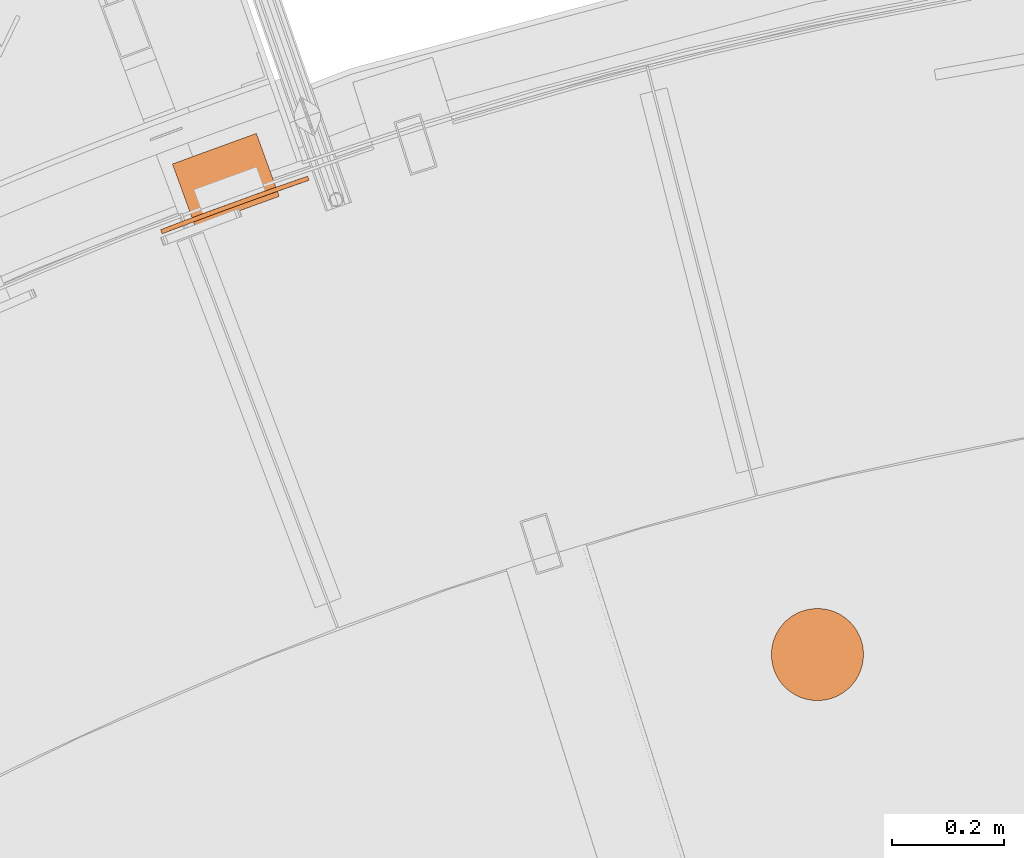
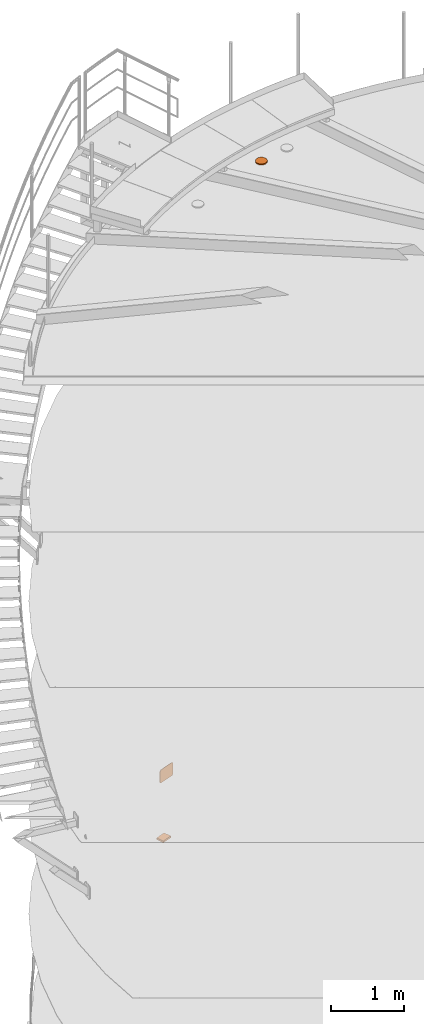
# One storey, part 87 of 126: 3 proxies.
"""IFC2X3 building model written with IfcOpenShell, lengths in millimetres."""

from ifc_helpers import new_model, si_unit, origin, origin_with_axes, place, context, project, spatial, faceted_brep, material, element, save


model = new_model("IFC2X3")

# Units and contexts
context_of_model_1 = context(None, 3, precision=0.1, world=origin())
context_of_model_2 = context(None, 3, precision=0.1, world=origin())
ifc_project = project(units=[si_unit("LENGTHUNIT", "METRE", prefix="MILLI"), si_unit("AREAUNIT", "SQUARE_METRE", prefix="CENTI"), si_unit("VOLUMEUNIT", "CUBIC_METRE", prefix="CENTI"), si_unit("MASSUNIT", "GRAM", prefix="KILO")], contexts=[context_of_model_1, context_of_model_2])

# Site, building, storey
site_placement = place(None, origin_with_axes())
site = spatial("IfcSite", under=ifc_project, at=site_placement, CompositionType="ELEMENT")
building_placement = place(site_placement, origin_with_axes())
building = spatial("IfcBuilding", under=site, at=building_placement, CompositionType="ELEMENT")
storey_placement = place(building_placement, origin_with_axes())
storey = spatial("IfcBuildingStorey", under=building, at=storey_placement, CompositionType="ELEMENT")

# Proxies
ifc_material = material(Name="STAHL")
proxy_1_placement = place(storey_placement, origin_with_axes())
element("IfcBuildingElementProxy", 1, at=proxy_1_placement, inside=storey, material=ifc_material, Name="profile", context=context_of_model_2, shape_type="Brep", body=[
    faceted_brep([(6309.1, 14601.6, 10998.9), (6309.1, 14601.6, 10979.9), (6304.0, 14594.6, 10979.9), (6304.0, 14594.6, 10998.9), (6314.9, 14608.0, 10998.9), (6314.9, 14608.0, 10979.9), (6454.7, 14562.6, 10998.9), (6454.7, 14562.6, 10979.9), (6452.9, 14571.0, 10979.9), (6452.9, 14571.0, 10998.9), (6299.7, 14587.1, 10979.9), (6299.7, 14587.1, 10998.9), (6450.3, 14579.2, 10979.9), (6450.3, 14579.2, 10998.9), (6296.2, 14579.2, 10979.9), (6296.2, 14579.2, 10998.9), (6446.7, 14587.1, 10979.9), (6446.7, 14587.1, 10998.9), (6293.5, 14571.0, 10979.9), (6293.5, 14571.0, 10998.9), (6442.4, 14594.6, 10979.9), (6442.4, 14594.6, 10998.9), (6291.8, 14562.6, 10979.9), (6291.8, 14562.6, 10998.9), (6437.4, 14601.6, 10979.9), (6437.4, 14601.6, 10998.9), (6290.8, 14554.0, 10979.9), (6290.8, 14554.0, 10998.9), (6431.6, 14608.0, 10979.9), (6431.6, 14608.0, 10998.9), (6290.8, 14545.3, 10979.9), (6290.8, 14545.3, 10998.9), (6425.2, 14613.8, 10979.9), (6425.2, 14613.8, 10998.9), (6291.8, 14536.7, 10979.9), (6291.8, 14536.7, 10998.9), (6418.2, 14618.8, 10979.9), (6418.2, 14618.8, 10998.9), (6410.7, 14623.2, 10979.9), (6410.7, 14623.2, 10998.9), (6402.8, 14626.7, 10979.9), (6402.8, 14626.7, 10998.9), (6394.6, 14629.3, 10979.9), (6394.6, 14629.3, 10998.9), (6386.1, 14631.1, 10979.9), (6386.1, 14631.1, 10998.9), (6377.6, 14632.0, 10979.9), (6377.6, 14632.0, 10998.9), (6368.9, 14632.0, 10979.9), (6368.9, 14632.0, 10998.9), (6360.3, 14631.1, 10979.9), (6360.3, 14631.1, 10998.9), (6351.9, 14629.3, 10979.9), (6351.9, 14629.3, 10998.9), (6343.7, 14626.7, 10979.9), (6343.7, 14626.7, 10998.9), (6335.8, 14623.2, 10979.9), (6335.8, 14623.2, 10998.9), (6328.3, 14618.8, 10979.9), (6328.3, 14618.8, 10998.9), (6321.3, 14613.8, 10979.9), (6321.3, 14613.8, 10998.9), (6403.6, 14554.5, 10998.9), (6402.3, 14559.7, 10998.9), (6402.3, 14559.7, 10979.9), (6403.6, 14554.5, 10979.9), (6400.1, 14564.6, 10998.9), (6400.1, 14564.6, 10979.9), (6397.1, 14569.0, 10998.9), (6397.1, 14569.0, 10979.9), (6393.4, 14572.9, 10998.9), (6393.4, 14572.9, 10979.9), (6389.1, 14576.0, 10998.9), (6389.1, 14576.0, 10979.9), (6384.3, 14578.4, 10998.9), (6384.3, 14578.4, 10979.9), (6379.1, 14579.8, 10998.9), (6379.1, 14579.8, 10979.9), (6373.8, 14580.4, 10998.9), (6373.8, 14580.4, 10979.9), (6368.4, 14580.0, 10998.9), (6368.4, 14580.0, 10979.9), (6363.2, 14578.7, 10998.9), (6363.2, 14578.7, 10979.9), (6358.3, 14576.5, 10998.9), (6358.3, 14576.5, 10979.9), (6353.9, 14573.5, 10998.9), (6353.9, 14573.5, 10979.9), (6350.0, 14569.8, 10998.9), (6350.0, 14569.8, 10979.9), (6346.9, 14565.5, 10998.9), (6346.9, 14565.5, 10979.9), (6344.5, 14560.7, 10998.9), (6344.5, 14560.7, 10979.9), (6343.1, 14555.5, 10998.9), (6343.1, 14555.5, 10979.9), (6342.5, 14550.2, 10998.9), (6342.5, 14550.2, 10979.9), (6342.9, 14544.8, 10998.9), (6342.9, 14544.8, 10979.9), (6432.7, 14514.3, 10998.9), (6432.1, 14516.4, 10998.9), (6432.1, 14516.4, 10979.9), (6432.7, 14514.3, 10979.9), (6431.0, 14518.3, 10998.9), (6431.0, 14518.3, 10979.9), (6429.5, 14519.9, 10998.9), (6429.5, 14519.9, 10979.9), (6427.7, 14521.0, 10998.9), (6427.7, 14521.0, 10979.9), (6425.6, 14521.7, 10998.9), (6425.6, 14521.7, 10979.9), (6423.5, 14521.9, 10998.9), (6423.5, 14521.9, 10979.9), (6421.3, 14521.6, 10998.9), (6421.3, 14521.6, 10979.9), (6419.3, 14520.7, 10998.9), (6419.3, 14520.7, 10979.9), (6417.6, 14519.4, 10998.9), (6417.6, 14519.4, 10979.9), (6416.2, 14517.7, 10998.9), (6416.2, 14517.7, 10979.9), (6415.3, 14515.8, 10998.9), (6415.3, 14515.8, 10979.9), (6414.8, 14513.7, 10998.9), (6414.8, 14513.7, 10979.9), (6414.9, 14511.5, 10998.9), (6414.9, 14511.5, 10979.9), (6331.6, 14587.8, 10998.9), (6331.0, 14589.9, 10998.9), (6331.0, 14589.9, 10979.9), (6331.6, 14587.8, 10979.9), (6329.9, 14591.8, 10998.9), (6329.9, 14591.8, 10979.9), (6328.4, 14593.3, 10998.9), (6328.4, 14593.3, 10979.9), (6326.6, 14594.5, 10998.9), (6326.6, 14594.5, 10979.9), (6324.5, 14595.2, 10998.9), (6324.5, 14595.2, 10979.9), (6322.3, 14595.4, 10998.9), (6322.3, 14595.4, 10979.9), (6320.2, 14595.0, 10998.9), (6320.2, 14595.0, 10979.9), (6318.2, 14594.2, 10998.9), (6318.2, 14594.2, 10979.9), (6316.5, 14592.9, 10998.9), (6316.5, 14592.9, 10979.9), (6315.1, 14591.2, 10998.9), (6315.1, 14591.2, 10979.9), (6314.1, 14589.3, 10998.9), (6314.1, 14589.3, 10979.9), (6313.7, 14587.1, 10998.9), (6313.7, 14587.1, 10979.9), (6313.8, 14585.0, 10998.9), (6313.8, 14585.0, 10979.9), (6418.9, 14601.6, 10998.9), (6418.3, 14603.7, 10998.9), (6418.3, 14603.7, 10979.9), (6418.9, 14601.6, 10979.9), (6417.2, 14605.6, 10998.9), (6417.2, 14605.6, 10979.9), (6415.7, 14607.2, 10998.9), (6415.7, 14607.2, 10979.9), (6413.9, 14608.3, 10998.9), (6413.9, 14608.3, 10979.9), (6411.8, 14609.0, 10998.9), (6411.8, 14609.0, 10979.9), (6409.6, 14609.2, 10998.9), (6409.6, 14609.2, 10979.9), (6407.5, 14608.9, 10998.9), (6407.5, 14608.9, 10979.9), (6405.5, 14608.0, 10998.9), (6405.5, 14608.0, 10979.9), (6403.8, 14606.7, 10998.9), (6403.8, 14606.7, 10979.9), (6402.4, 14605.0, 10998.9), (6402.4, 14605.0, 10979.9), (6401.4, 14603.1, 10998.9), (6401.4, 14603.1, 10979.9), (6401.0, 14601.0, 10998.9), (6401.0, 14601.0, 10979.9), (6401.1, 14598.8, 10998.9), (6401.1, 14598.8, 10979.9), (6345.4, 14500.5, 10998.9), (6344.8, 14502.6, 10998.9), (6344.8, 14502.6, 10979.9), (6345.4, 14500.5, 10979.9), (6343.7, 14504.5, 10998.9), (6343.7, 14504.5, 10979.9), (6342.2, 14506.0, 10998.9), (6342.2, 14506.0, 10979.9), (6340.4, 14507.2, 10998.9), (6340.4, 14507.2, 10979.9), (6338.3, 14507.9, 10998.9), (6338.3, 14507.9, 10979.9), (6336.2, 14508.1, 10998.9), (6336.2, 14508.1, 10979.9), (6334.0, 14507.7, 10998.9), (6334.0, 14507.7, 10979.9), (6332.0, 14506.9, 10998.9), (6332.0, 14506.9, 10979.9), (6330.3, 14505.6, 10998.9), (6330.3, 14505.6, 10979.9), (6328.9, 14503.9, 10998.9), (6328.9, 14503.9, 10979.9), (6328.0, 14502.0, 10998.9), (6328.0, 14502.0, 10979.9), (6327.5, 14499.8, 10998.9), (6327.5, 14499.8, 10979.9), (6327.6, 14497.7, 10998.9), (6327.6, 14497.7, 10979.9), (6328.2, 14495.6, 10998.9), (6328.2, 14495.6, 10979.9), (6329.3, 14493.7, 10998.9), (6329.3, 14493.7, 10979.9), (6330.8, 14492.1, 10998.9), (6330.8, 14492.1, 10979.9), (6332.6, 14491.0, 10998.9), (6332.6, 14491.0, 10979.9), (6334.7, 14490.3, 10998.9), (6334.7, 14490.3, 10979.9), (6336.8, 14490.1, 10998.9), (6336.8, 14490.1, 10979.9), (6339.0, 14490.4, 10998.9), (6339.0, 14490.4, 10979.9), (6341.0, 14491.3, 10998.9), (6341.0, 14491.3, 10979.9), (6342.7, 14492.6, 10998.9), (6342.7, 14492.6, 10979.9), (6344.1, 14494.2, 10998.9), (6344.1, 14494.2, 10979.9), (6345.0, 14496.2, 10998.9), (6345.0, 14496.2, 10979.9), (6345.5, 14498.3, 10998.9), (6345.5, 14498.3, 10979.9), (6401.7, 14596.7, 10998.9), (6401.7, 14596.7, 10979.9), (6402.8, 14594.8, 10998.9), (6402.8, 14594.8, 10979.9), (6404.3, 14593.3, 10998.9), (6404.3, 14593.3, 10979.9), (6406.1, 14592.1, 10998.9), (6406.1, 14592.1, 10979.9), (6408.1, 14591.4, 10998.9), (6408.1, 14591.4, 10979.9), (6410.3, 14591.2, 10998.9), (6410.3, 14591.2, 10979.9), (6412.4, 14591.6, 10998.9), (6412.4, 14591.6, 10979.9), (6414.4, 14592.4, 10998.9), (6414.4, 14592.4, 10979.9), (6416.2, 14593.7, 10998.9), (6416.2, 14593.7, 10979.9), (6417.6, 14595.4, 10998.9), (6417.6, 14595.4, 10979.9), (6418.5, 14597.3, 10998.9), (6418.5, 14597.3, 10979.9), (6418.9, 14599.4, 10998.9), (6418.9, 14599.4, 10979.9), (6314.4, 14582.9, 10998.9), (6314.4, 14582.9, 10979.9), (6315.5, 14581.0, 10998.9), (6315.5, 14581.0, 10979.9), (6317.0, 14579.4, 10998.9), (6317.0, 14579.4, 10979.9), (6318.8, 14578.3, 10998.9), (6318.8, 14578.3, 10979.9), (6320.8, 14577.6, 10998.9), (6320.8, 14577.6, 10979.9), (6323.0, 14577.4, 10998.9), (6323.0, 14577.4, 10979.9), (6325.1, 14577.7, 10998.9), (6325.1, 14577.7, 10979.9), (6327.1, 14578.6, 10998.9), (6327.1, 14578.6, 10979.9), (6328.9, 14579.9, 10998.9), (6328.9, 14579.9, 10979.9), (6330.3, 14581.5, 10998.9), (6330.3, 14581.5, 10979.9), (6331.2, 14583.5, 10998.9), (6331.2, 14583.5, 10979.9), (6331.6, 14585.6, 10998.9), (6331.6, 14585.6, 10979.9), (6415.5, 14509.4, 10998.9), (6415.5, 14509.4, 10979.9), (6416.6, 14507.5, 10998.9), (6416.6, 14507.5, 10979.9), (6418.1, 14506.0, 10998.9), (6418.1, 14506.0, 10979.9), (6419.9, 14504.8, 10998.9), (6419.9, 14504.8, 10979.9), (6422.0, 14504.1, 10998.9), (6422.0, 14504.1, 10979.9), (6424.1, 14503.9, 10998.9), (6424.1, 14503.9, 10979.9), (6426.3, 14504.3, 10998.9), (6426.3, 14504.3, 10979.9), (6428.3, 14505.1, 10998.9), (6428.3, 14505.1, 10979.9), (6430.0, 14506.4, 10998.9), (6430.0, 14506.4, 10979.9), (6431.4, 14508.1, 10998.9), (6431.4, 14508.1, 10979.9), (6432.3, 14510.0, 10998.9), (6432.3, 14510.0, 10979.9), (6432.8, 14512.1, 10998.9), (6432.8, 14512.1, 10979.9), (6368.9, 14467.3, 10998.9), (6377.6, 14467.3, 10998.9), (6386.1, 14468.2, 10998.9), (6394.6, 14470.0, 10998.9), (6402.8, 14472.6, 10998.9), (6410.7, 14476.1, 10998.9), (6418.2, 14480.5, 10998.9), (6425.2, 14485.5, 10998.9), (6431.6, 14491.3, 10998.9), (6437.4, 14497.7, 10998.9), (6442.4, 14504.7, 10998.9), (6446.7, 14512.2, 10998.9), (6450.3, 14520.1, 10998.9), (6452.9, 14528.3, 10998.9), (6404.0, 14549.1, 10998.9), (6403.4, 14543.8, 10998.9), (6401.9, 14538.6, 10998.9), (6399.6, 14533.8, 10998.9), (6396.4, 14529.5, 10998.9), (6392.6, 14525.7, 10998.9), (6388.1, 14522.8, 10998.9), (6383.2, 14520.6, 10998.9), (6378.0, 14519.3, 10998.9), (6372.7, 14518.9, 10998.9), (6367.4, 14519.5, 10998.9), (6362.2, 14520.9, 10998.9), (6357.4, 14523.3, 10998.9), (6353.1, 14526.4, 10998.9), (6349.3, 14530.3, 10998.9), (6346.3, 14534.7, 10998.9), (6344.2, 14539.6, 10998.9), (6454.7, 14536.7, 10998.9), (6455.6, 14545.3, 10998.9), (6455.6, 14554.0, 10998.9), (6293.5, 14528.3, 10998.9), (6296.2, 14520.1, 10998.9), (6299.7, 14512.2, 10998.9), (6304.0, 14504.7, 10998.9), (6309.1, 14497.7, 10998.9), (6314.9, 14491.3, 10998.9), (6321.3, 14485.5, 10998.9), (6328.3, 14480.5, 10998.9), (6335.8, 14476.1, 10998.9), (6343.7, 14472.6, 10998.9), (6351.9, 14470.0, 10998.9), (6360.3, 14468.2, 10998.9), (6368.9, 14467.3, 10979.9), (6360.3, 14468.2, 10979.9), (6351.9, 14470.0, 10979.9), (6343.7, 14472.6, 10979.9), (6335.8, 14476.1, 10979.9), (6328.3, 14480.5, 10979.9), (6321.3, 14485.5, 10979.9), (6314.9, 14491.3, 10979.9), (6309.1, 14497.7, 10979.9), (6304.0, 14504.7, 10979.9), (6299.7, 14512.2, 10979.9), (6296.2, 14520.1, 10979.9), (6293.5, 14528.3, 10979.9), (6455.6, 14554.0, 10979.9), (6455.6, 14545.3, 10979.9), (6454.7, 14536.7, 10979.9), (6452.9, 14528.3, 10979.9), (6383.2, 14520.6, 10979.9), (6388.1, 14522.8, 10979.9), (6392.6, 14525.7, 10979.9), (6396.4, 14529.5, 10979.9), (6399.6, 14533.8, 10979.9), (6401.9, 14538.6, 10979.9), (6403.4, 14543.8, 10979.9), (6404.0, 14549.1, 10979.9), (6344.2, 14539.6, 10979.9), (6346.3, 14534.7, 10979.9), (6349.3, 14530.3, 10979.9), (6353.1, 14526.4, 10979.9), (6357.4, 14523.3, 10979.9), (6362.2, 14520.9, 10979.9), (6367.4, 14519.5, 10979.9), (6372.7, 14518.9, 10979.9), (6378.0, 14519.3, 10979.9), (6450.3, 14520.1, 10979.9), (6446.7, 14512.2, 10979.9), (6442.4, 14504.7, 10979.9), (6437.4, 14497.7, 10979.9), (6431.6, 14491.3, 10979.9), (6425.2, 14485.5, 10979.9), (6418.2, 14480.5, 10979.9), (6410.7, 14476.1, 10979.9), (6402.8, 14472.6, 10979.9), (6394.6, 14470.0, 10979.9), (6386.1, 14468.2, 10979.9), (6377.6, 14467.3, 10979.9)], [[[0, 1, 2, 3]], [[0, 4, 5, 1]], [[6, 7, 8, 9]], [[3, 2, 10, 11]], [[9, 8, 12, 13]], [[11, 10, 14, 15]], [[13, 12, 16, 17]], [[15, 14, 18, 19]], [[17, 16, 20, 21]], [[19, 18, 22, 23]], [[21, 20, 24, 25]], [[23, 22, 26, 27]], [[25, 24, 28, 29]], [[27, 26, 30, 31]], [[29, 28, 32, 33]], [[31, 30, 34, 35]], [[33, 32, 36, 37]], [[37, 36, 38, 39]], [[39, 38, 40, 41]], [[41, 40, 42, 43]], [[43, 42, 44, 45]], [[45, 44, 46, 47]], [[47, 46, 48, 49]], [[49, 48, 50, 51]], [[51, 50, 52, 53]], [[53, 52, 54, 55]], [[55, 54, 56, 57]], [[57, 56, 58, 59]], [[59, 58, 60, 61]], [[61, 60, 5, 4]], [[62, 63, 64, 65]], [[63, 66, 67, 64]], [[66, 68, 69, 67]], [[68, 70, 71, 69]], [[70, 72, 73, 71]], [[72, 74, 75, 73]], [[74, 76, 77, 75]], [[76, 78, 79, 77]], [[78, 80, 81, 79]], [[80, 82, 83, 81]], [[82, 84, 85, 83]], [[84, 86, 87, 85]], [[86, 88, 89, 87]], [[88, 90, 91, 89]], [[90, 92, 93, 91]], [[92, 94, 95, 93]], [[94, 96, 97, 95]], [[96, 98, 99, 97]], [[100, 101, 102, 103]], [[101, 104, 105, 102]], [[104, 106, 107, 105]], [[106, 108, 109, 107]], [[108, 110, 111, 109]], [[110, 112, 113, 111]], [[112, 114, 115, 113]], [[114, 116, 117, 115]], [[116, 118, 119, 117]], [[118, 120, 121, 119]], [[120, 122, 123, 121]], [[122, 124, 125, 123]], [[126, 127, 125, 124]], [[128, 129, 130, 131]], [[129, 132, 133, 130]], [[132, 134, 135, 133]], [[134, 136, 137, 135]], [[136, 138, 139, 137]], [[138, 140, 141, 139]], [[140, 142, 143, 141]], [[142, 144, 145, 143]], [[144, 146, 147, 145]], [[146, 148, 149, 147]], [[148, 150, 151, 149]], [[150, 152, 153, 151]], [[154, 155, 153, 152]], [[156, 157, 158, 159]], [[157, 160, 161, 158]], [[160, 162, 163, 161]], [[162, 164, 165, 163]], [[164, 166, 167, 165]], [[166, 168, 169, 167]], [[168, 170, 171, 169]], [[170, 172, 173, 171]], [[172, 174, 175, 173]], [[174, 176, 177, 175]], [[176, 178, 179, 177]], [[178, 180, 181, 179]], [[182, 183, 181, 180]], [[184, 185, 186, 187]], [[185, 188, 189, 186]], [[188, 190, 191, 189]], [[190, 192, 193, 191]], [[192, 194, 195, 193]], [[194, 196, 197, 195]], [[196, 198, 199, 197]], [[198, 200, 201, 199]], [[200, 202, 203, 201]], [[202, 204, 205, 203]], [[204, 206, 207, 205]], [[206, 208, 209, 207]], [[210, 211, 209, 208]], [[210, 212, 213, 211]], [[214, 215, 213, 212]], [[216, 217, 215, 214]], [[218, 219, 217, 216]], [[220, 221, 219, 218]], [[222, 223, 221, 220]], [[224, 225, 223, 222]], [[226, 227, 225, 224]], [[228, 229, 227, 226]], [[230, 231, 229, 228]], [[232, 233, 231, 230]], [[234, 235, 233, 232]], [[184, 187, 235, 234]], [[182, 236, 237, 183]], [[238, 239, 237, 236]], [[240, 241, 239, 238]], [[242, 243, 241, 240]], [[244, 245, 243, 242]], [[246, 247, 245, 244]], [[248, 249, 247, 246]], [[250, 251, 249, 248]], [[252, 253, 251, 250]], [[254, 255, 253, 252]], [[256, 257, 255, 254]], [[258, 259, 257, 256]], [[156, 159, 259, 258]], [[154, 260, 261, 155]], [[260, 262, 263, 261]], [[262, 264, 265, 263]], [[264, 266, 267, 265]], [[266, 268, 269, 267]], [[268, 270, 271, 269]], [[270, 272, 273, 271]], [[272, 274, 275, 273]], [[274, 276, 277, 275]], [[276, 278, 279, 277]], [[278, 280, 281, 279]], [[280, 282, 283, 281]], [[282, 128, 131, 283]], [[126, 284, 285, 127]], [[284, 286, 287, 285]], [[286, 288, 289, 287]], [[288, 290, 291, 289]], [[290, 292, 293, 291]], [[292, 294, 295, 293]], [[294, 296, 297, 295]], [[296, 298, 299, 297]], [[298, 300, 301, 299]], [[300, 302, 303, 301]], [[302, 304, 305, 303]], [[304, 306, 307, 305]], [[306, 100, 103, 307]], [[308, 309, 310, 311, 312, 313, 314, 315, 316, 317, 318, 319, 320, 321, 106, 104, 101, 100, 306, 304, 302, 300, 298, 296, 294, 292, 290, 288, 286, 284, 126, 124, 122, 120, 118, 116, 114, 112, 110, 322, 323, 324, 325, 326, 327, 328, 329, 330, 331, 332, 333, 334, 335, 336, 337, 338, 200, 198, 196, 194, 192, 190, 188, 185, 184, 234, 232, 230, 228, 226, 224, 222, 220, 218, 216, 214, 212, 210, 208, 206, 204, 202, 200, 338, 98, 96, 94, 92, 90, 88, 86, 84, 82, 129, 128, 282, 280, 278, 276, 274, 272, 270, 268, 266, 264, 262, 260, 154, 152, 150, 148, 146, 144, 142, 140, 138, 136, 134, 132, 129, 82, 80, 78, 76, 74, 72, 70, 68, 66, 63, 250, 248, 246, 244, 242, 240, 238, 236, 182, 180, 178, 176, 174, 172, 170, 168, 166, 164, 162, 160, 157, 156, 258, 256, 254, 252, 250, 63, 62, 322, 110, 108, 106, 321, 339, 340, 341, 6, 9, 13, 17, 21, 25, 29, 33, 37, 39, 41, 43, 45, 47, 49, 51, 53, 55, 57, 59, 61, 4, 0, 3, 11, 15, 19, 23, 27, 31, 35, 342, 343, 344, 345, 346, 347, 348, 349, 350, 351, 352, 353]], [[354, 355, 356, 357, 358, 359, 360, 361, 362, 363, 364, 365, 366, 34, 30, 26, 22, 18, 14, 10, 2, 1, 5, 60, 58, 56, 54, 52, 50, 48, 46, 44, 42, 40, 38, 36, 32, 28, 24, 20, 16, 12, 8, 7, 367, 368, 369, 370, 107, 109, 111, 113, 115, 117, 119, 121, 123, 125, 127, 285, 371, 372, 373, 374, 375, 376, 377, 378, 65, 64, 67, 69, 71, 73, 75, 77, 79, 181, 183, 237, 239, 241, 243, 245, 247, 249, 251, 253, 255, 257, 259, 159, 158, 161, 163, 165, 167, 169, 171, 173, 175, 177, 179, 181, 79, 81, 83, 85, 87, 89, 91, 93, 95, 97, 269, 271, 273, 275, 277, 279, 281, 283, 131, 130, 133, 135, 137, 139, 141, 143, 145, 147, 149, 151, 153, 155, 261, 263, 265, 267, 269, 97, 99, 379, 380, 381, 382, 383, 384, 385, 386, 235, 187, 186, 189, 191, 193, 195, 197, 199, 201, 203, 205, 207, 209, 211, 213, 215, 217, 219, 221, 223, 225, 227, 229, 231, 233, 235, 386, 387, 371, 285, 287, 289, 291, 293, 295, 297, 299, 301, 303, 305, 307, 103, 102, 105, 107, 370, 388, 389, 390, 391, 392, 393, 394, 395, 396, 397, 398, 399]], [[338, 379, 99, 98]], [[337, 380, 379, 338]], [[336, 381, 380, 337]], [[335, 382, 381, 336]], [[334, 383, 382, 335]], [[333, 384, 383, 334]], [[332, 385, 384, 333]], [[331, 386, 385, 332]], [[330, 387, 386, 331]], [[329, 371, 387, 330]], [[328, 372, 371, 329]], [[327, 373, 372, 328]], [[326, 374, 373, 327]], [[325, 375, 374, 326]], [[324, 376, 375, 325]], [[323, 377, 376, 324]], [[322, 378, 377, 323]], [[62, 65, 378, 322]], [[314, 313, 395, 394]], [[315, 314, 394, 393]], [[316, 315, 393, 392]], [[342, 35, 34, 366]], [[317, 316, 392, 391]], [[343, 342, 366, 365]], [[318, 317, 391, 390]], [[344, 343, 365, 364]], [[319, 318, 390, 389]], [[345, 344, 364, 363]], [[320, 319, 389, 388]], [[346, 345, 363, 362]], [[321, 320, 388, 370]], [[347, 346, 362, 361]], [[339, 321, 370, 369]], [[348, 347, 361, 360]], [[340, 339, 369, 368]], [[349, 348, 360, 359]], [[341, 340, 368, 367]], [[350, 349, 359, 358]], [[6, 341, 367, 7]], [[351, 350, 358, 357]], [[352, 351, 357, 356]], [[353, 352, 356, 355]], [[308, 353, 355, 354]], [[309, 308, 354, 399]], [[310, 309, 399, 398]], [[311, 310, 398, 397]], [[312, 311, 397, 396]], [[313, 312, 396, 395]]]),
])
proxy_2_placement = place(storey_placement, origin_with_axes())
element("IfcBuildingElementProxy", 2, at=proxy_2_placement, inside=storey, material=ifc_material, Name="profile", context=context_of_model_2, shape_type="Brep", body=[
    faceted_brep([(5450.5, 15394.7, 704.7), (5454.5, 15396.1, 701.2), (5451.9, 15403.7, 701.2), (5447.5, 15402.1, 705.0), (5445.8, 15393.1, 707.5), (5442.3, 15400.3, 707.9), (5440.2, 15391.2, 709.4), (5437.1, 15398.5, 709.5), (5222.5, 15311.9, 709.5), (5227.7, 15313.9, 710.0), (5296.4, 15339.6, 710.0), (5365.3, 15364.7, 710.0), (5434.5, 15389.2, 710.0), (5431.9, 15396.7, 710.0), (5362.6, 15372.3, 710.0), (5293.6, 15347.1, 710.0), (5224.8, 15321.4, 710.0), (5219.2, 15319.2, 709.4), (5204.5, 15305.1, 697.0), (5207.8, 15306.3, 701.2), (5205.0, 15313.8, 701.2), (5201.4, 15312.4, 696.5), (5202.0, 15304.1, 692.0), (5198.7, 15311.4, 691.0), (5200.2, 15303.4, 686.0), (5197.2, 15310.8, 685.5), (5199.6, 15303.2, 680.0), (5196.8, 15310.6, 680.0), (5196.8, 15310.6, 520.0), (5197.3, 15310.9, 514.0), (5200.1, 15303.4, 514.5), (5199.6, 15303.2, 520.0), (5447.9, 15402.3, 495.3), (5451.9, 15403.7, 498.8), (5454.5, 15396.1, 498.8), (5450.1, 15394.6, 495.0), (5443.2, 15400.7, 492.5), (5444.9, 15392.8, 492.1), (5437.6, 15398.7, 490.6), (5439.7, 15391.0, 490.5), (5222.0, 15311.7, 490.6), (5219.6, 15319.4, 490.5), (5224.8, 15321.4, 490.0), (5293.6, 15347.1, 490.0), (5362.6, 15372.3, 490.0), (5431.9, 15396.7, 490.0), (5434.5, 15389.2, 490.0), (5365.3, 15364.7, 490.0), (5296.4, 15339.6, 490.0), (5227.7, 15313.9, 490.0), (5201.7, 15312.5, 503.0), (5205.0, 15313.8, 498.8), (5207.8, 15306.3, 498.8), (5204.3, 15305.0, 503.5), (5199.1, 15311.5, 508.0), (5201.6, 15303.9, 509.0), (5214.5, 15317.5, 492.1), (5216.5, 15309.6, 492.5), (5209.4, 15315.5, 495.0), (5211.8, 15307.8, 495.3), (5462.3, 15398.8, 514.0), (5459.8, 15406.4, 514.5), (5460.2, 15406.5, 520.0), (5460.2, 15406.5, 680.0), (5459.7, 15406.3, 686.0), (5462.4, 15398.8, 685.5), (5462.8, 15399.0, 680.0), (5462.8, 15399.0, 520.0), (5458.3, 15405.9, 509.0), (5460.5, 15398.2, 508.0), (5455.6, 15404.9, 503.5), (5457.9, 15397.3, 503.0), (5217.4, 15310.0, 707.9), (5213.6, 15317.1, 707.5), (5212.2, 15308.0, 705.0), (5208.9, 15315.3, 704.7), (5460.9, 15398.3, 691.0), (5457.9, 15405.7, 692.0), (5458.2, 15397.4, 696.5), (5455.3, 15404.8, 697.0)], [[[0, 1, 2, 3]], [[4, 0, 3, 5]], [[6, 4, 5, 7]], [[8, 9, 10, 11, 12, 6, 7, 13, 14, 15, 16, 17]], [[18, 19, 20, 21]], [[22, 18, 21, 23]], [[24, 22, 23, 25]], [[26, 24, 25, 27, 28, 29, 30, 31]], [[32, 33, 34, 35]], [[36, 32, 35, 37]], [[38, 36, 37, 39]], [[40, 41, 42, 43, 44, 45, 38, 39, 46, 47, 48, 49]], [[50, 51, 52, 53]], [[54, 50, 53, 55]], [[29, 54, 55, 30]], [[56, 41, 40, 57]], [[58, 56, 57, 59]], [[51, 58, 59, 52]], [[60, 61, 62, 63, 64, 65, 66, 67]], [[68, 61, 60, 69]], [[70, 68, 69, 71]], [[33, 70, 71, 34]], [[72, 8, 17, 73]], [[74, 72, 73, 75]], [[19, 74, 75, 20]], [[76, 65, 64, 77]], [[78, 76, 77, 79]], [[1, 78, 79, 2]], [[26, 31, 30, 55, 53, 52, 59, 57, 40, 49, 48, 47, 46, 39, 37, 35, 34, 71, 69, 60, 67, 66, 65, 76, 78, 1, 0, 4, 6, 12, 11, 10, 9, 8, 72, 74, 19, 18, 22, 24]], [[28, 27, 25, 23, 21, 20, 75, 73, 17, 16, 15, 14, 13, 7, 5, 3, 2, 79, 77, 64, 63, 62, 61, 68, 70, 33, 32, 36, 38, 45, 44, 43, 42, 41, 56, 58, 51, 50, 54, 29]]]),
])
proxy_3_placement = place(storey_placement, origin_with_axes())
element("IfcBuildingElementProxy", 3, at=proxy_3_placement, inside=storey, material=ifc_material, Name="profile", context=context_of_model_2, shape_type="Brep", body=[
    faceted_brep([(5259.1, 15315.5, -530.0), (5218.0, 15428.3, -530.0), (5368.4, 15483.0, -530.0), (5409.4, 15370.2, -530.0), (5218.0, 15428.3, -500.0), (5368.4, 15483.0, -500.0), (5259.1, 15315.5, -500.0), (5409.4, 15370.2, -500.0)], [[[0, 1, 2, 3]], [[1, 4, 5, 2]], [[4, 6, 7, 5]], [[6, 0, 3, 7]], [[1, 0, 6, 4]], [[7, 3, 2, 5]]]),
])

save(model, "model.ifc")
